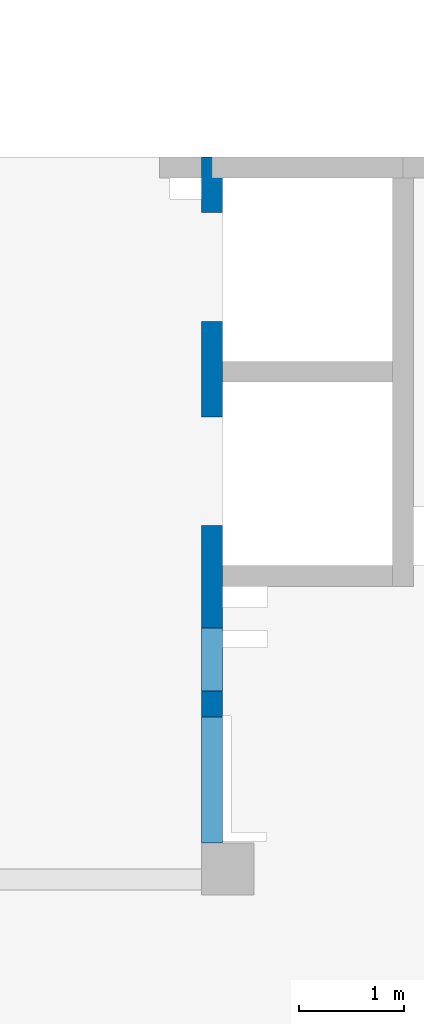
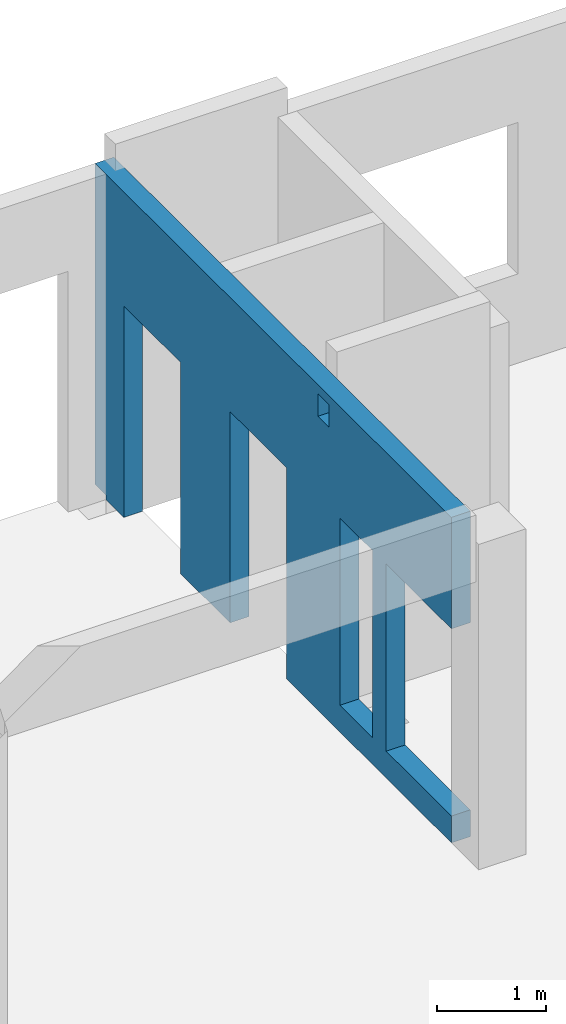
# One storey, part 90 of 93: 1 wall, 5 openings.
"""IFC4 building model written with IfcOpenShell, lengths in millimetres."""

from ifc_helpers import new_model, entity, si_unit, converted_unit, derived_unit, direction, frame, origin, place, context, subcontext, project, spatial, indexed_curve, outline, extrude, polygons, material, type_object, element, save


model = new_model("IFC4")

# Units and contexts
model_context = context("Model", 3, precision=0.01, world=origin(), true_north=direction((6.12303176911189e-17, 1.0)))
plan_context = context("Plan", 3, precision=0.01, world=origin(), true_north=direction((6.12303176911189e-17, 1.0)))
body_context = subcontext(model_context, "Body", "Model", "MODEL_VIEW")
ifc_project = project(units=[si_unit("LENGTHUNIT", "METRE", prefix="MILLI"), si_unit("AREAUNIT", "SQUARE_METRE"), si_unit("VOLUMEUNIT", "CUBIC_METRE"), converted_unit("PLANEANGLEUNIT", "DEGREE", entity("IfcRatioMeasure", 0.0174532925199433), si_unit("PLANEANGLEUNIT", "RADIAN"), dimensions=[0, 0, 0, 0, 0, 0, 0]), si_unit("MASSUNIT", "GRAM", prefix="KILO"), derived_unit("MASSDENSITYUNIT", [(si_unit("MASSUNIT", "GRAM", prefix="KILO"), 1), (si_unit("LENGTHUNIT", "METRE"), -3)]), derived_unit("MOMENTOFINERTIAUNIT", [(si_unit("LENGTHUNIT", "METRE"), 4)]), si_unit("TIMEUNIT", "SECOND"), si_unit("FREQUENCYUNIT", "HERTZ"), si_unit("THERMODYNAMICTEMPERATUREUNIT", "DEGREE_CELSIUS"), derived_unit("THERMALTRANSMITTANCEUNIT", [(si_unit("MASSUNIT", "GRAM", prefix="KILO"), 1), (si_unit("THERMODYNAMICTEMPERATUREUNIT", "KELVIN"), -1), (si_unit("TIMEUNIT", "SECOND"), -3)]), derived_unit("VOLUMETRICFLOWRATEUNIT", [(si_unit("LENGTHUNIT", "METRE"), 3), (si_unit("TIMEUNIT", "SECOND"), -1)]), derived_unit("MASSFLOWRATEUNIT", [(si_unit("MASSUNIT", "GRAM", prefix="KILO"), 1), (si_unit("TIMEUNIT", "SECOND"), -1)]), derived_unit("ROTATIONALFREQUENCYUNIT", [(si_unit("TIMEUNIT", "SECOND"), -1)]), si_unit("ELECTRICCURRENTUNIT", "AMPERE"), si_unit("ELECTRICVOLTAGEUNIT", "VOLT"), si_unit("POWERUNIT", "WATT"), si_unit("FORCEUNIT", "NEWTON", prefix="KILO"), si_unit("ILLUMINANCEUNIT", "LUX"), si_unit("LUMINOUSFLUXUNIT", "LUMEN"), si_unit("LUMINOUSINTENSITYUNIT", "CANDELA"), derived_unit("USERDEFINED", [(si_unit("MASSUNIT", "GRAM", prefix="KILO"), -1), (si_unit("LENGTHUNIT", "METRE"), -2), (si_unit("TIMEUNIT", "SECOND"), 3), (si_unit("LUMINOUSFLUXUNIT", "LUMEN"), 1)]), derived_unit("LINEARVELOCITYUNIT", [(si_unit("LENGTHUNIT", "METRE"), 1), (si_unit("TIMEUNIT", "SECOND"), -1)]), si_unit("PRESSUREUNIT", "PASCAL"), derived_unit("USERDEFINED", [(si_unit("LENGTHUNIT", "METRE"), -2), (si_unit("MASSUNIT", "GRAM", prefix="KILO"), 1), (si_unit("TIMEUNIT", "SECOND"), -2)]), derived_unit("LINEARFORCEUNIT", [(si_unit("MASSUNIT", "GRAM", prefix="KILO"), 1), (si_unit("LENGTHUNIT", "METRE"), 1), (si_unit("TIMEUNIT", "SECOND"), -2), (si_unit("LENGTHUNIT", "METRE"), -1)]), derived_unit("PLANARFORCEUNIT", [(si_unit("MASSUNIT", "GRAM", prefix="KILO"), 1), (si_unit("LENGTHUNIT", "METRE"), 1), (si_unit("TIMEUNIT", "SECOND"), -2), (si_unit("LENGTHUNIT", "METRE"), -2)])], contexts=[model_context, plan_context])

# Site, building, storey
site_placement = place(None, origin())
site = spatial("IfcSite", under=ifc_project, at=site_placement, CompositionType="ELEMENT")
building_placement = place(site_placement, origin())
building = spatial("IfcBuilding", under=site, at=building_placement, CompositionType="ELEMENT")
storey_placement = place(building_placement, frame((0.0, 0.0, 15900.0)))
storey = spatial("IfcBuildingStorey", under=building, at=storey_placement, CompositionType="ELEMENT", Elevation=15900.0)

# Wall, openings
ifc_material = material()
wall_type = type_object("IfcWallType", PredefinedType="STANDARD")
wall_placement = place(storey_placement, frame((16000.0002685547, 20499.9998657227, -150.0), z_axis=(0.0, 0.0, 1.0), x_axis=(0.0, -1.0, 0.0)))
wall = element("IfcWall", 1, at=wall_placement, inside=storey, type_object=wall_type, material=ifc_material, PredefinedType="NOTDEFINED", context=body_context, shape_type="Tessellation", body=[
    polygons([(4100.00063936683, -100.000000000321, 3550.0), (4300.00063936683, -100.00000000032, 3550.0), (4300.00063936683, -100.00000000032, 3300.00000000001), (4100.00063936683, -100.000000000321, 3300.00000000001), (4500.00063936683, -99.9999999999995, 2399.99999999999), (5100.00063936683, -100.000000000001, 2399.99999999999), (5100.00063936683, -100.000000000001, 299.999999999999), (4500.00063936683, -99.9999999999995, 299.999999999999), (6550.00048980714, -99.9999999999982, 3650.0), (399.999999999983, -99.9999999999998, 3650.0), (199.999999999985, -100.0, 3650.0), (0.0, -100.0, 3650.0), (0.0, -100.0, 49.9999999999995), (200.000000000002, -100.0, 49.9999999999995), (200.000000000002, -100.0, -2.16573425859679e-12), (529.999999999996, -99.9999999999995, -2.16573425859679e-12), (529.999999999996, -99.9999999999995, 2369.99999999805), (1570.0, -100.000000000002, 2369.99999999805), (1570.0, -100.000000000002, -2.16573425859679e-12), (2480.0, -100.000000000001, -2.16573425859679e-12), (2480.0, -100.000000000001, 2369.99999999805), (3519.99999999999, -100.000000000001, 2369.99999999805), (3519.99999999999, -100.000000000001, -2.16573425859679e-12), (6550.00048980714, -99.9999999999982, -2.16573425859679e-12), (6550.00048980714, -99.9999999999982, 299.999999999999), (5350.00048980714, -100.0, 299.999999999999), (5350.00048980714, -100.0, 2399.99999999999), (6550.00048980714, -99.9999999999982, 2399.99999999999), (4300.00063936683, 100.0, 3550.0), (4100.00063936683, 99.9999999999999, 3550.0), (4100.00063936683, 99.9999999999999, 3300.00000000001), (4300.00063936683, 100.0, 3300.00000000001), (5100.00063936683, 99.9999999999994, 2399.99999999999), (4500.00063936683, 99.9999999999984, 2399.99999999998), (4500.00063936683, 99.9999999999984, 299.999999999999), (5100.00063936683, 99.9999999999994, 299.999999999999), (0.0, 99.9999999999996, 3650.0), (1950.0, 100.000000000001, 3650.0), (2150.0, 99.9999999999988, 3650.0), (3900.00063936683, 99.9999999999995, 3650.0), (4100.00063936682, 99.9999999999999, 3650.0), (4350.00063936682, 100.0, 3650.0), (4525.00063936682, 100.000000000001, 3650.0), (4675.00063936683, 99.9999999999987, 3650.0), (6450.00063936682, 99.9999999999994, 3650.0), (6530.00063936682, 99.9999999999996, 3650.0), (6550.00048980714, 99.9999999999996, 3650.0), (6550.00048980714, 99.9999999999996, 2399.99999999999), (5350.00048980714, 99.9999999999998, 2399.99999999998), (5350.00048980714, 99.9999999999998, 299.999999999999), (6550.00048980714, 99.9999999999996, 299.999999999999), (6550.00048980714, 99.9999999999996, -2.16573425859679e-12), (4100.00063936683, 99.9999999999999, 0.0), (3900.00063936683, 99.9999999999995, 0.0), (3519.99999999999, 99.9999999999989, -2.16573425859679e-12), (3519.99999999999, 99.9999999999989, 2369.99999999805), (2480.0, 100.000000000002, 2369.99999999804), (2480.0, 100.000000000002, -2.16573425859679e-12), (1570.0, 100.0, -2.16573425859679e-12), (1570.0, 100.0, 2369.99999999805), (529.999999999996, 100.0, 2369.99999999804), (529.999999999996, 100.0, -2.16573425859679e-12), (200.000000000002, 99.9999999999999, -2.16573425859679e-12), (200.000000000002, 99.9999999999999, 49.9999999999995), (0.0, 99.9999999999996, 49.9999999999995), (200.000000000002, 9.88347789881356e-13, 49.9999999999973), (0.0, 6.56688670961758e-13, 49.9999999999973)], [[[9, 10, 11, 12, 13, 14, 15, 16, 17, 18, 19, 20, 21, 22, 23, 24, 25, 26, 27, 28], [1, 2, 3, 4], [5, 6, 7, 8]], [[37, 38, 39, 40, 41, 42, 43, 44, 45, 46, 47, 48, 49, 50, 51, 52, 53, 54, 55, 56, 57, 58, 59, 60, 61, 62, 63, 64, 65], [29, 30, 31, 32], [33, 34, 35, 36]], [[16, 15, 63, 62]], [[24, 52, 51, 25]], [[12, 11, 10, 9, 47, 46, 45, 44, 43, 42, 41, 40, 39, 38, 37]], [[2, 1, 30, 29]], [[2, 29, 32, 3]], [[3, 32, 31, 4]], [[30, 1, 4, 31]], [[33, 6, 5, 34]], [[34, 5, 8, 35]], [[35, 8, 7, 36]], [[6, 33, 36, 7]], [[27, 49, 48, 28]], [[49, 27, 26, 50]], [[50, 26, 25, 51]], [[56, 22, 21, 57]], [[57, 21, 20, 58]], [[22, 56, 55, 23]], [[60, 18, 17, 61]], [[61, 17, 16, 62]], [[18, 60, 59, 19]], [[65, 64, 66, 14, 13, 67]], [[15, 14, 66, 64, 63]], [[13, 12, 37, 65, 67]], [[47, 9, 28, 48]], [[58, 20, 19, 59]], [[52, 24, 23, 55, 54, 53]]], closed=True),
])
opening_1_placement = place(wall_placement, frame((20499.9998657227, -16000.0002685547, 150.0), z_axis=(0.0, 0.0, 1.0), x_axis=(0.0, 1.0, 0.0)))
element("IfcOpeningElement", 2, at=opening_1_placement, cuts=wall, PredefinedType="OPENING", context=body_context, shape_type="SweptSolid", body=[
    extrude(outline(indexed_curve([(-1049.99999999999, -600.0), (1049.99999999999, -600.0), (1049.99999999999, 600.0), (-1049.99999999999, 600.0), (-1049.99999999999, -600.0)], self_intersect=False)), frame((15800.0002685547, 14549.9993759155, 1200.0), z_axis=(1.0, 0.0, 0.0), x_axis=(0.0, 0.0, -1.0)), (0.0, 0.0, 1.0), 400.000000001943),
])
opening_2_placement = place(wall_placement, frame((20499.9998657227, -16000.0002685547, 150.0), z_axis=(0.0, 0.0, 1.0), x_axis=(0.0, 1.0, 0.0)))
element("IfcOpeningElement", 3, at=opening_2_placement, cuts=wall, PredefinedType="OPENING", context=body_context, shape_type="SweptSolid", body=[
    extrude(outline(indexed_curve([(-1184.99999999902, -520.000000000001), (1184.99999999902, -520.000000000001), (1184.99999999902, 519.999999999999), (-1184.99999999902, 519.999999999999), (-1184.99999999902, -520.000000000001)], self_intersect=False)), frame((15800.0002685547, 17499.9998657227, 1035.0), z_axis=(1.0, 0.0, 0.0), x_axis=(0.0, 0.0, -1.0)), (0.0, 0.0, 1.0), 400.000000001943),
])
opening_3_placement = place(wall_placement, frame((20499.9998657227, -16000.0002685547, 150.0), z_axis=(0.0, 0.0, 1.0), x_axis=(0.0, 1.0, 0.0)))
element("IfcOpeningElement", 4, at=opening_3_placement, cuts=wall, PredefinedType="OPENING", context=body_context, shape_type="SweptSolid", body=[
    extrude(outline(indexed_curve([(-1184.99999999902, -519.999999999999), (1184.99999999902, -519.999999999999), (1184.99999999902, 520.000000000001), (-1184.99999999902, 520.000000000001), (-1184.99999999902, -519.999999999999)], self_intersect=False)), frame((15800.0002685547, 19449.9998657227, 1035.0), z_axis=(1.0, 0.0, 0.0), x_axis=(0.0, 0.0, -1.0)), (0.0, 0.0, 1.0), 400.000000001943),
])
opening_4_placement = place(wall_placement, frame((20499.9998657227, -16000.0002685547, 150.0), z_axis=(0.0, 0.0, 1.0), x_axis=(0.0, 1.0, 0.0)))
element("IfcOpeningElement", 5, at=opening_4_placement, cuts=wall, PredefinedType="OPENING", context=body_context, shape_type="SweptSolid", body=[
    extrude(outline(indexed_curve([(-100.000000000001, -124.999999999993), (99.9999999999989, -124.999999999993), (99.9999999999989, 124.999999999993), (-100.000000000001, 124.999999999993), (-100.000000000001, -124.999999999993)], self_intersect=False)), frame((15900.0002685537, 16299.9992263558, 3275.0), z_axis=(1.0, 0.0, 0.0), x_axis=(0.0, -1.0, 0.0)), (0.0, 0.0, 1.0), 200.000000000962),
])
opening_5_placement = place(wall_placement, frame((20499.9998657227, -16000.0002685547, 150.0), z_axis=(0.0, 0.0, 1.0), x_axis=(0.0, 1.0, 0.0)))
element("IfcOpeningElement", 6, at=opening_5_placement, cuts=wall, PredefinedType="OPENING", context=body_context, shape_type="SweptSolid", body=[
    extrude(outline(indexed_curve([(-1049.99999999999, -300.000000000001), (1049.99999999999, -300.000000000001), (1049.99999999999, 299.999999999999), (-1049.99999999999, 299.999999999999), (-1049.99999999999, -300.000000000001)], self_intersect=False)), frame((15800.0002685547, 15699.9992263558, 1200.0), z_axis=(1.0, 0.0, 0.0), x_axis=(0.0, 0.0, -1.0)), (0.0, 0.0, 1.0), 400.000000001943),
])

save(model, "model.ifc")
